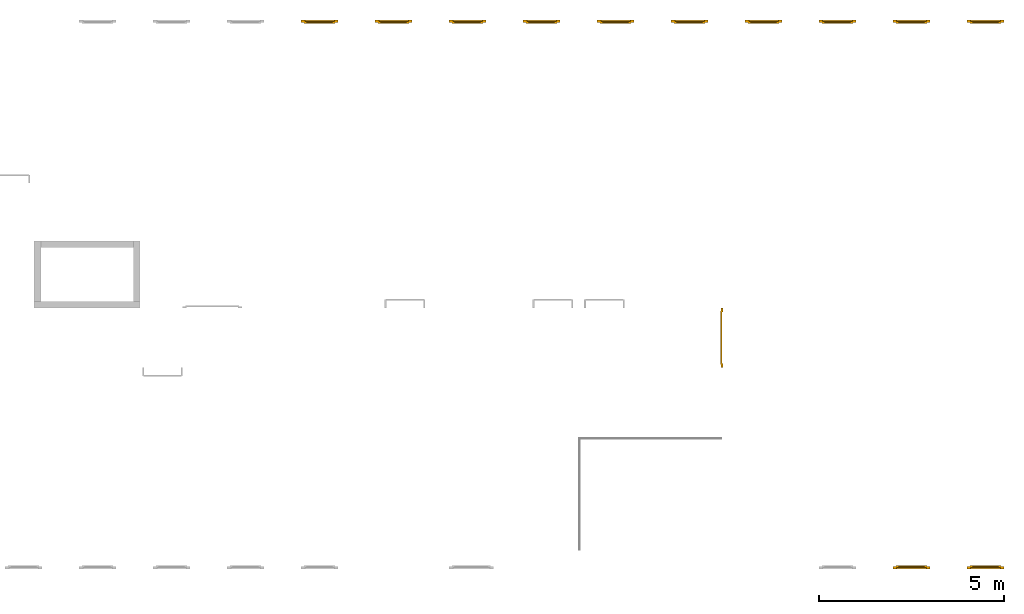
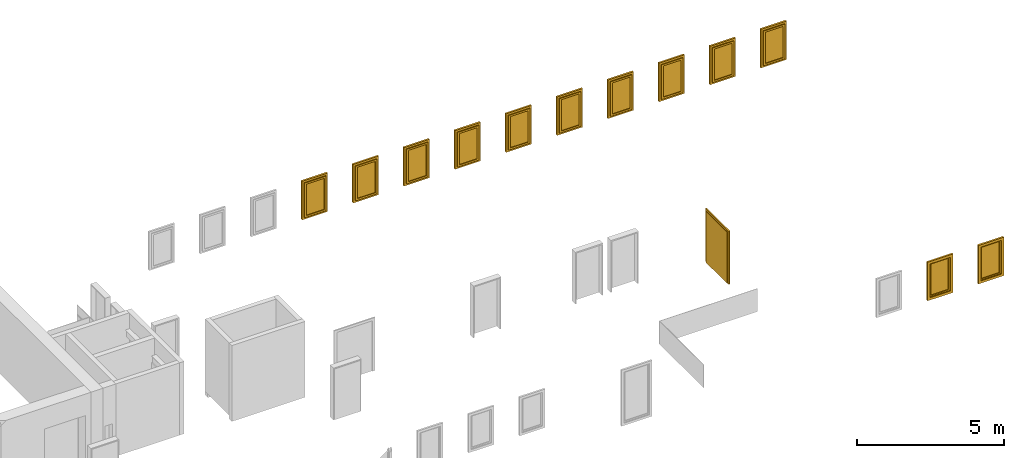
# One storey, part 4 of 5: 12 windows, 1 door.
"""IFC4 building model written with IfcOpenShell, lengths in metres."""

import ifcopenshell
import ifcopenshell.guid

model = None  # the IFC model being written
_history = None  # IfcOwnerHistory: only IFC2X3 demands one
_inside = {}  # id of a spatial element -> (the spatial element, [elements in it])
_under = {}  # id of a project, library or spatial element -> (it, [spatial elements below it])
_declared = {}  # id of a project -> (the project, [libraries it declares])
_typed = {}  # id of a type object -> (the type object, [elements of that type])
_made_of = {}  # id of a material, layer set ... -> (it, [elements and type objects made of it])


def new_model(schema):
    """Start an empty IFC model of exactly this schema.

    Asked for "IFC4X3", IfcOpenShell would pick the latest addendum, in which some entities
    have other attributes; the version numbers below select the first issue.
    IFC2X3 requires an IfcOwnerHistory on every rooted entity: one is made here for all.
    """
    global model, _history
    if schema == "IFC4X3":
        model = ifcopenshell.file(schema_version=(4, 3, 0, 0))
    else:
        model = ifcopenshell.file(schema=schema)
    _inside.clear()
    _under.clear()
    _declared.clear()
    _typed.clear()
    _made_of.clear()
    _history = None
    if model.schema == "IFC2X3":
        org = make("IfcOrganization", Name="unknown")
        user = make(
            "IfcPersonAndOrganization",
            ThePerson=make("IfcPerson", FamilyName="unknown"),
            TheOrganization=org,
        )
        app = make(
            "IfcApplication",
            ApplicationDeveloper=org,
            Version="unknown",
            ApplicationFullName="unknown",
            ApplicationIdentifier="unknown",
        )
        _history = make(
            "IfcOwnerHistory",
            OwningUser=user,
            OwningApplication=app,
            ChangeAction="ADDED",
            CreationDate=0,
        )
    return model


def make(cls, **values):
    """One entity of the class cls with the attributes given. An attribute that is None is left unset."""
    return model.create_entity(
        cls, **{name: value for name, value in values.items() if value is not None}
    )


def entity(cls, *values):
    """Any entity or typed value of the class cls, its attributes in the order of the schema. None: left unset."""
    e = model.create_entity(cls)
    for i, value in enumerate(values):
        if value is not None:
            e[i] = value
    return e


def rooted(cls, **values):
    """An entity with a GlobalId (a new one), such as an element, a storey or a relation."""
    return make(cls, GlobalId=ifcopenshell.guid.new(), OwnerHistory=_history, **values)


def si_unit(unit_type, name, prefix=None):
    """IfcSIUnit, for example si_unit("LENGTHUNIT", "METRE", prefix="MILLI")."""
    return make("IfcSIUnit", UnitType=unit_type, Prefix=prefix, Name=name)


def converted_unit(unit_type, name, factor, base, dimensions=None, offset=None):
    """IfcConversionBasedUnit, such as the inch: factor (a typed value) times the base unit."""
    return make(
        "IfcConversionBasedUnit"
        if offset is None
        else "IfcConversionBasedUnitWithOffset",
        ConversionOffset=offset,
        Dimensions=None
        if dimensions is None
        else entity("IfcDimensionalExponents", *dimensions),
        UnitType=unit_type,
        Name=name,
        ConversionFactor=make(
            "IfcMeasureWithUnit", ValueComponent=factor, UnitComponent=base
        ),
    )


def derived_unit(unit_type, elements):
    """IfcDerivedUnit: a product of units, each with its exponent."""
    return make(
        "IfcDerivedUnit",
        Elements=[
            make("IfcDerivedUnitElement", Unit=unit, Exponent=power)
            for unit, power in elements
        ],
        UnitType=unit_type,
    )


def assignment(units):
    """IfcUnitAssignment: the units of a project."""
    return None if units is None else make("IfcUnitAssignment", Units=units)


def point(xyz):
    """IfcCartesianPoint."""
    return None if xyz is None else make("IfcCartesianPoint", Coordinates=xyz)


def direction(xyz):
    """IfcDirection."""
    return None if xyz is None else make("IfcDirection", DirectionRatios=xyz)


def frame(location, z_axis=None, x_axis=None):
    """IfcAxis2Placement3D, a coordinate frame: its origin and axes. An axis left out is left unset."""
    return make(
        "IfcAxis2Placement3D",
        Location=point(location),
        Axis=direction(z_axis),
        RefDirection=direction(x_axis),
    )


def origin_with_axes():
    """The frame at (0, 0, 0) with the z axis (0, 0, 1) and the x axis (1, 0, 0) written out."""
    return frame((0.0, 0.0, 0.0), z_axis=(0.0, 0.0, 1.0), x_axis=(1.0, 0.0, 0.0))


def place(relative_to, where):
    """IfcLocalPlacement: puts the frame where relative to a parent placement (None: the world)."""
    return make(
        "IfcLocalPlacement", PlacementRelTo=relative_to, RelativePlacement=where
    )


def context(
    kind, dimensions, precision=None, world=None, true_north=None, identifier=None
):
    """IfcGeometricRepresentationContext, for example the 3D "Model" context."""
    return make(
        "IfcGeometricRepresentationContext",
        ContextIdentifier=identifier,
        ContextType=kind,
        CoordinateSpaceDimension=dimensions,
        Precision=precision,
        WorldCoordinateSystem=world,
        TrueNorth=true_north,
    )


def subcontext(parent, identifier, kind, view, scale=None):
    """IfcGeometricRepresentationSubContext, for example "Body" below "Model"."""
    return make(
        "IfcGeometricRepresentationSubContext",
        ContextIdentifier=identifier,
        ContextType=kind,
        ParentContext=parent,
        TargetScale=scale,
        TargetView=view,
    )


def project(units=None, contexts=None):
    """IfcProject with its units and contexts."""
    return rooted(
        "IfcProject",
        Name="project",
        RepresentationContexts=contexts,
        UnitsInContext=assignment(units),
    )


def spatial(cls, under=None, at=None, **own):
    """A site, building, storey or space (cls), placed at a placement, below another one or the project."""
    s = rooted(cls, ObjectPlacement=at, **own)
    if under is not None:
        _under.setdefault(under.id(), (under, []))[1].append(s)
    return s


def point_list(points):
    """IfcCartesianPointList2D or 3D."""
    cls = (
        "IfcCartesianPointList2D" if len(points[0]) == 2 else "IfcCartesianPointList3D"
    )
    return make(cls, CoordList=points)


def polygons(points, faces, closed=None, point_numbers=None):
    """IfcPolygonalFaceSet: a face is its outer loop, then its inner loops; points numbered from 1."""
    made = []
    for loops in faces:
        if len(loops) == 1:
            made.append(make("IfcIndexedPolygonalFace", CoordIndex=loops[0]))
        else:
            made.append(
                make(
                    "IfcIndexedPolygonalFaceWithVoids",
                    CoordIndex=loops[0],
                    InnerCoordIndices=loops[1:],
                )
            )
    return make(
        "IfcPolygonalFaceSet",
        Coordinates=point_list(points),
        Closed=closed,
        Faces=made,
        PnIndex=point_numbers,
    )


def shape(context_of_items, identifier, shape_type, items):
    """IfcShapeRepresentation: the items that make up one representation, for example the "Body"."""
    return make(
        "IfcShapeRepresentation",
        ContextOfItems=context_of_items,
        RepresentationIdentifier=identifier,
        RepresentationType=shape_type,
        Items=items,
    )


def source(mapping_origin, context_of_items, identifier, shape_type, items):
    """IfcRepresentationMap: a shape defined once, which mapped items show again and again."""
    return make(
        "IfcRepresentationMap",
        MappingOrigin=mapping_origin,
        MappedRepresentation=shape(context_of_items, identifier, shape_type, items),
    )


def transform(
    local_origin,
    x_axis=None,
    y_axis=None,
    z_axis=None,
    scale=None,
    scale2=None,
    scale3=None,
    uniform=True,
):
    """IfcCartesianTransformationOperator3D, or its non-uniform kind. x_axis, y_axis, z_axis: its Axis1, 2, 3."""
    if uniform:
        return make(
            "IfcCartesianTransformationOperator3D",
            Axis1=direction(x_axis),
            Axis2=direction(y_axis),
            LocalOrigin=point(local_origin),
            Scale=scale,
            Axis3=direction(z_axis),
        )
    return make(
        "IfcCartesianTransformationOperator3DnonUniform",
        Axis1=direction(x_axis),
        Axis2=direction(y_axis),
        LocalOrigin=point(local_origin),
        Scale=scale,
        Axis3=direction(z_axis),
        Scale2=scale2,
        Scale3=scale3,
    )


def mapped(mapping_source, mapping_target):
    """IfcMappedItem: shows the shape of a source again, moved by a transform."""
    return make(
        "IfcMappedItem", MappingSource=mapping_source, MappingTarget=mapping_target
    )


def made_of(thing, what):
    """Note that an element or type object is made of a material, layer set ...; save() writes the relation."""
    if what is not None:
        _made_of.setdefault(what.id(), (what, []))[1].append(thing)
    return thing


def type_object(cls, material=None, **own):
    """A type object (cls), such as IfcWallType, which elements share."""
    return made_of(rooted(cls, **own), material)


def element(
    cls,
    number,
    at=None,
    inside=None,
    cuts=None,
    type_object=None,
    material=None,
    context=None,
    identifier="Body",
    shape_type=None,
    held_by="IfcProductDefinitionShape",
    body=None,
    shapes=None,
    **own,
):
    """One element of the class cls, such as IfcWall. Its Tag is "e" and its number.

    at: its placement. inside: the storey or other place that contains it. cuts: it is an
    opening in that element (IfcRelVoidsElement). A single representation is given by context,
    identifier, shape_type and body (its items); several are given by shapes. held_by: the class
    of the entity that holds the representations. save() writes the other relations.
    """
    e = rooted(cls, Tag="e%d" % number, ObjectPlacement=at, **own)
    if body is not None:
        shapes = [shape(context, identifier, shape_type, body)]
    if shapes is not None:
        e.Representation = make(held_by, Representations=shapes)
    if inside is not None:
        _inside.setdefault(inside.id(), (inside, []))[1].append(e)
    if cuts is not None:
        rooted(
            "IfcRelVoidsElement", RelatingBuildingElement=cuts, RelatedOpeningElement=e
        )
    if type_object is not None:
        _typed.setdefault(type_object.id(), (type_object, []))[1].append(e)
    return made_of(e, material)


def aggregate(whole, parts):
    """IfcRelAggregates: a whole, such as a stair, and the parts it consists of."""
    return rooted("IfcRelAggregates", RelatingObject=whole, RelatedObjects=parts)


def save(model, path):
    """Write the relations noted so far, then the file.

    IfcRelAggregates (storeys below a building ...), IfcRelContainedInSpatialStructure (elements
    in a storey), IfcRelDefinesByType, IfcRelAssociatesMaterial and IfcRelDeclares: one each for
    every whole, place, type object, material and project.
    """
    for whole, parts in _under.values():
        aggregate(whole, parts)
    for where, things in _inside.values():
        rooted(
            "IfcRelContainedInSpatialStructure",
            RelatedElements=things,
            RelatingStructure=where,
        )
    for kind, things in _typed.values():
        rooted("IfcRelDefinesByType", RelatedObjects=things, RelatingType=kind)
    for what, things in _made_of.values():
        rooted("IfcRelAssociatesMaterial", RelatedObjects=things, RelatingMaterial=what)
    for by, libraries in _declared.values():
        rooted("IfcRelDeclares", RelatingContext=by, RelatedDefinitions=libraries)
    model.write(path)


model = new_model("IFC4")

# Units and contexts
model_context = context("Model", 3, precision=1e-05, world=origin_with_axes(), true_north=direction((0.0, 1.0)))
body_context = subcontext(model_context, "Body", "Model", "MODEL_VIEW")
ifc_project = project(units=[si_unit("LENGTHUNIT", "METRE"), si_unit("AREAUNIT", "SQUARE_METRE"), si_unit("VOLUMEUNIT", "CUBIC_METRE"), converted_unit("PLANEANGLEUNIT", "DEGREE", entity("IfcPlaneAngleMeasure", 0.0174532925199433), si_unit("PLANEANGLEUNIT", "RADIAN"), dimensions=[0, 0, 0, 0, 0, 0, 0]), converted_unit("TIMEUNIT", "Year", entity("IfcTimeMeasure", 31557600.0), si_unit("TIMEUNIT", "SECOND"), dimensions=[0, 0, 1, 0, 0, 0, 0]), si_unit("MASSUNIT", "GRAM", prefix="KILO"), si_unit("THERMODYNAMICTEMPERATUREUNIT", "DEGREE_CELSIUS"), si_unit("LUMINOUSINTENSITYUNIT", "LUMEN"), si_unit("ENERGYUNIT", "JOULE", prefix="MEGA"), derived_unit("THERMALCONDUCTANCEUNIT", [(si_unit("POWERUNIT", "WATT"), 1), (si_unit("LENGTHUNIT", "METRE"), -1), (si_unit("THERMODYNAMICTEMPERATUREUNIT", "KELVIN"), -1)]), derived_unit("SPECIFICHEATCAPACITYUNIT", [(si_unit("ENERGYUNIT", "JOULE"), 1), (si_unit("MASSUNIT", "GRAM", prefix="KILO"), -1), (si_unit("THERMODYNAMICTEMPERATUREUNIT", "KELVIN"), -1)]), derived_unit("MASSDENSITYUNIT", [(si_unit("MASSUNIT", "GRAM", prefix="KILO"), 1), (si_unit("VOLUMEUNIT", "CUBIC_METRE"), -1)])], contexts=[model_context])

# Site, building, storey
site_placement = place(None, origin_with_axes())
site = spatial("IfcSite", under=ifc_project, at=site_placement, CompositionType="ELEMENT")
building_placement = place(None, origin_with_axes())
building = spatial("IfcBuilding", under=site, at=building_placement, CompositionType="ELEMENT")
storey_placement = place(None, frame((0.0, 0.0, 4.5), z_axis=(0.0, 0.0, 1.0), x_axis=(1.0, 0.0, 0.0)))
storey = spatial("IfcBuildingStorey", under=building, at=storey_placement, Name="1 OG", CompositionType="ELEMENT", Elevation=4.5)

# Windows
window_type = type_object("IfcWindowType", Name="1-27", PartitioningType="SINGLE_PANEL", PredefinedType="WINDOW")
shared_shape_1 = source(origin_with_axes(), body_context, "Body", "Tessellation", [
    polygons([(-0.5, -0.07, 0.0), (-0.5, 0.0, 0.0), (-0.4, 0.0, 0.1), (-0.4, -0.07, 0.1), (-0.5, -0.07, 1.6), (-0.5, 0.0, 1.6), (-0.4, 0.0, 1.5), (-0.4, -0.07, 1.5)], [[[1, 2, 3, 4]], [[5, 6, 2, 1]], [[2, 6, 7, 3]], [[4, 3, 7, 8]], [[1, 4, 8, 5]], [[8, 7, 6, 5]]], closed=True),
    polygons([(0.5, -0.07, 0.0), (0.5, 0.0, 0.0), (0.5, 0.0, 1.6), (0.5, -0.07, 1.6), (0.4, -0.07, 0.1), (0.4, 0.0, 0.1), (0.4, 0.0, 1.5), (0.4, -0.07, 1.5)], [[[1, 2, 3, 4]], [[5, 6, 2, 1]], [[2, 6, 7, 3]], [[4, 3, 7, 8]], [[1, 4, 8, 5]], [[8, 7, 6, 5]]], closed=True),
    polygons([(-0.5, -0.07, 0.0), (-0.5, 0.0, 0.0), (0.5, 0.0, 0.0), (0.5, -0.07, 0.0), (-0.4, -0.07, 0.1), (-0.4, 0.0, 0.1), (0.0, 0.0, 0.1), (0.4, 0.0, 0.1), (0.4, -0.07, 0.1), (0.0, -0.07, 0.1)], [[[1, 2, 3, 4]], [[5, 6, 2, 1]], [[2, 6, 7, 8, 3]], [[4, 3, 8, 9]], [[1, 4, 9, 10, 5]], [[10, 7, 6, 5]], [[9, 8, 7, 10]]], closed=True),
    polygons([(-0.5, -0.07, 1.6), (-0.5, 0.0, 1.6), (-0.4, 0.0, 1.5), (-0.4, -0.07, 1.5), (0.5, -0.07, 1.6), (0.5, 0.0, 1.6), (0.4, 0.0, 1.5), (0.0, 0.0, 1.5), (0.0, -0.07, 1.5), (0.4, -0.07, 1.5)], [[[1, 2, 3, 4]], [[5, 6, 2, 1]], [[2, 6, 7, 8, 3]], [[4, 3, 8, 9]], [[1, 4, 9, 10, 5]], [[10, 7, 6, 5]], [[9, 8, 7, 10]]], closed=True),
    polygons([(-0.42, 0.0, 0.08), (-0.42, 0.03, 0.08), (-0.35, 0.03, 0.15), (-0.35, 0.0, 0.15), (-0.42, 0.0, 1.52), (-0.42, 0.03, 1.52), (-0.35, 0.03, 1.45), (-0.35, 0.0, 1.45)], [[[1, 2, 3, 4]], [[5, 6, 2, 1]], [[2, 6, 7, 3]], [[4, 3, 7, 8]], [[1, 4, 8, 5]], [[8, 7, 6, 5]]], closed=True),
    polygons([(0.42, 0.0, 0.08), (0.35, 0.0, 0.15), (0.35, 0.03, 0.15), (0.42, 0.03, 0.08), (0.42, 0.0, 1.52), (0.35, 0.0, 1.45), (0.35, 0.03, 1.45), (0.42, 0.03, 1.52)], [[[1, 2, 3, 4]], [[1, 5, 6, 2]], [[2, 6, 7, 3]], [[4, 3, 7, 8]], [[5, 1, 4, 8]], [[6, 5, 8, 7]]], closed=True),
    polygons([(-0.42, 0.0, 0.08), (-0.42, 0.03, 0.08), (0.42, 0.03, 0.08), (0.42, 0.0, 0.08), (-0.35, 0.0, 0.15), (-0.35, 0.03, 0.15), (0.35, 0.03, 0.15), (0.35, 0.0, 0.15)], [[[1, 2, 3, 4]], [[5, 6, 2, 1]], [[2, 6, 7, 3]], [[4, 3, 7, 8]], [[1, 4, 8, 5]], [[8, 7, 6, 5]]], closed=True),
    polygons([(-0.42, 0.0, 1.52), (0.42, 0.0, 1.52), (0.42, 0.03, 1.52), (-0.42, 0.03, 1.52), (-0.35, 0.0, 1.45), (0.35, 0.0, 1.45), (0.35, 0.03, 1.45), (-0.35, 0.03, 1.45)], [[[1, 2, 3, 4]], [[1, 5, 6, 2]], [[2, 6, 7, 3]], [[4, 3, 7, 8]], [[5, 1, 4, 8]], [[6, 5, 8, 7]]], closed=True),
    polygons([(-0.4, -0.03, 0.1), (-0.4, 0.0, 0.1), (-0.35, 0.0, 0.15), (-0.35, -0.03, 0.15), (-0.4, -0.03, 1.5), (-0.4, 0.0, 1.5), (-0.35, 0.0, 1.45), (-0.35, -0.03, 1.45)], [[[1, 2, 3, 4]], [[5, 6, 2, 1]], [[2, 6, 7, 3]], [[4, 3, 7, 8]], [[1, 4, 8, 5]], [[8, 7, 6, 5]]], closed=True),
    polygons([(0.4, -0.03, 0.1), (0.35, -0.03, 0.15), (0.35, 0.0, 0.15), (0.4, 0.0, 0.1), (0.4, -0.03, 1.5), (0.35, -0.03, 1.45), (0.35, 0.0, 1.45), (0.4, 0.0, 1.5)], [[[1, 2, 3, 4]], [[1, 5, 6, 2]], [[2, 6, 7, 3]], [[4, 3, 7, 8]], [[5, 1, 4, 8]], [[6, 5, 8, 7]]], closed=True),
    polygons([(-0.4, -0.03, 0.1), (-0.4, 0.0, 0.1), (0.4, 0.0, 0.1), (0.4, -0.03, 0.1), (-0.35, -0.03, 0.15), (-0.35, 0.0, 0.15), (0.35, 0.0, 0.15), (0.35, -0.03, 0.15)], [[[1, 2, 3, 4]], [[5, 6, 2, 1]], [[2, 6, 7, 3]], [[4, 3, 7, 8]], [[1, 4, 8, 5]], [[8, 7, 6, 5]]], closed=True),
    polygons([(-0.4, -0.03, 1.5), (0.4, -0.03, 1.5), (0.4, 0.0, 1.5), (-0.4, 0.0, 1.5), (-0.35, -0.03, 1.45), (0.35, -0.03, 1.45), (0.35, 0.0, 1.45), (-0.35, 0.0, 1.45)], [[[1, 2, 3, 4]], [[1, 5, 6, 2]], [[2, 6, 7, 3]], [[4, 3, 7, 8]], [[5, 1, 4, 8]], [[6, 5, 8, 7]]], closed=True),
    polygons([(-0.35, -0.00500000000000001, 0.15), (-0.35, 0.00499999999999999, 0.15), (0.35, 0.00499999999999999, 0.15), (0.35, -0.00500000000000001, 0.15), (-0.35, -0.00500000000000001, 1.45), (-0.35, 0.00499999999999999, 1.45), (0.35, 0.00499999999999999, 1.45), (0.35, -0.00500000000000001, 1.45)], [[[1, 2, 3, 4]], [[5, 6, 2, 1]], [[2, 6, 7, 3]], [[4, 3, 7, 8]], [[1, 4, 8, 5]], [[8, 7, 6, 5]]], closed=True),
])
window_1_placement = place(None, frame((58.723, 0.0, 5.5), z_axis=(0.0, 0.0, 1.0), x_axis=(1.0, 0.0, 0.0)))
element("IfcWindow", 1, at=window_1_placement, inside=storey, type_object=window_type, Name="Fenster-001", OverallHeight=1.6, OverallWidth=1.0, context=body_context, shape_type="MappedRepresentation", body=[
    mapped(shared_shape_1, transform((0.5, 0.07, 0.0))),
])
window_2_placement = place(None, frame((56.723, 0.0, 5.5), z_axis=(0.0, 0.0, 1.0), x_axis=(1.0, 0.0, 0.0)))
element("IfcWindow", 2, at=window_2_placement, inside=storey, type_object=window_type, Name="Fenster-001", OverallHeight=1.6, OverallWidth=1.0, context=body_context, shape_type="MappedRepresentation", body=[
    mapped(shared_shape_1, transform((0.5, 0.0700000000000004, 0.0))),
])
shared_shape_2 = source(origin_with_axes(), body_context, "Body", "Tessellation", [
    polygons([(0.5, -0.07, 0.0), (0.4, -0.07, 0.1), (0.4, 0.0, 0.1), (0.5, 0.0, 0.0), (0.5, -0.07, 1.6), (0.4, -0.07, 1.5), (0.4, 0.0, 1.5), (0.5, 0.0, 1.6)], [[[1, 2, 3, 4]], [[1, 5, 6, 2]], [[2, 6, 7, 3]], [[4, 3, 7, 8]], [[5, 1, 4, 8]], [[6, 5, 8, 7]]], closed=True),
    polygons([(-0.5, -0.07, 0.0), (-0.5, -0.07, 1.6), (-0.5, 0.0, 1.6), (-0.5, 0.0, 0.0), (-0.4, -0.07, 0.1), (-0.4, -0.07, 1.5), (-0.4, 0.0, 1.5), (-0.4, 0.0, 0.1)], [[[1, 2, 3, 4]], [[1, 5, 6, 2]], [[2, 6, 7, 3]], [[4, 3, 7, 8]], [[5, 1, 4, 8]], [[6, 5, 8, 7]]], closed=True),
    polygons([(0.5, -0.07, 0.0), (-0.5, -0.07, 0.0), (-0.5, 0.0, 0.0), (0.5, 0.0, 0.0), (0.4, -0.07, 0.1), (0.0, -0.07, 0.1), (-0.4, -0.07, 0.1), (-0.4, 0.0, 0.1), (0.0, 0.0, 0.1), (0.4, 0.0, 0.1)], [[[1, 2, 3, 4]], [[1, 5, 6, 7, 2]], [[2, 7, 8, 3]], [[4, 3, 8, 9, 10]], [[5, 1, 4, 10]], [[6, 5, 10, 9]], [[7, 6, 9, 8]]], closed=True),
    polygons([(0.5, -0.07, 1.6), (0.4, -0.07, 1.5), (0.4, 0.0, 1.5), (0.5, 0.0, 1.6), (-0.5, -0.07, 1.6), (-0.4, -0.07, 1.5), (0.0, -0.07, 1.5), (0.0, 0.0, 1.5), (-0.4, 0.0, 1.5), (-0.5, 0.0, 1.6)], [[[1, 2, 3, 4]], [[1, 5, 6, 7, 2]], [[2, 7, 8, 3]], [[4, 3, 8, 9, 10]], [[5, 1, 4, 10]], [[6, 5, 10, 9]], [[7, 6, 9, 8]]], closed=True),
    polygons([(0.42, 0.0, 0.08), (0.35, 0.0, 0.15), (0.35, 0.03, 0.15), (0.42, 0.03, 0.08), (0.42, 0.0, 1.52), (0.35, 0.0, 1.45), (0.35, 0.03, 1.45), (0.42, 0.03, 1.52)], [[[1, 2, 3, 4]], [[1, 5, 6, 2]], [[2, 6, 7, 3]], [[4, 3, 7, 8]], [[5, 1, 4, 8]], [[6, 5, 8, 7]]], closed=True),
    polygons([(-0.42, 0.0, 0.08), (-0.42, 0.03, 0.08), (-0.35, 0.03, 0.15), (-0.35, 0.0, 0.15), (-0.42, 0.0, 1.52), (-0.42, 0.03, 1.52), (-0.35, 0.03, 1.45), (-0.35, 0.0, 1.45)], [[[1, 2, 3, 4]], [[5, 6, 2, 1]], [[2, 6, 7, 3]], [[4, 3, 7, 8]], [[1, 4, 8, 5]], [[8, 7, 6, 5]]], closed=True),
    polygons([(0.42, 0.0, 0.08), (-0.42, 0.0, 0.08), (-0.42, 0.03, 0.08), (0.42, 0.03, 0.08), (0.35, 0.0, 0.15), (-0.35, 0.0, 0.15), (-0.35, 0.03, 0.15), (0.35, 0.03, 0.15)], [[[1, 2, 3, 4]], [[1, 5, 6, 2]], [[2, 6, 7, 3]], [[4, 3, 7, 8]], [[5, 1, 4, 8]], [[6, 5, 8, 7]]], closed=True),
    polygons([(0.42, 0.0, 1.52), (0.42, 0.03, 1.52), (-0.42, 0.03, 1.52), (-0.42, 0.0, 1.52), (0.35, 0.0, 1.45), (0.35, 0.03, 1.45), (-0.35, 0.03, 1.45), (-0.35, 0.0, 1.45)], [[[1, 2, 3, 4]], [[5, 6, 2, 1]], [[2, 6, 7, 3]], [[4, 3, 7, 8]], [[1, 4, 8, 5]], [[8, 7, 6, 5]]], closed=True),
    polygons([(0.4, -0.03, 0.1), (0.35, -0.03, 0.15), (0.35, 0.0, 0.15), (0.4, 0.0, 0.1), (0.4, -0.03, 1.5), (0.35, -0.03, 1.45), (0.35, 0.0, 1.45), (0.4, 0.0, 1.5)], [[[1, 2, 3, 4]], [[1, 5, 6, 2]], [[2, 6, 7, 3]], [[4, 3, 7, 8]], [[5, 1, 4, 8]], [[6, 5, 8, 7]]], closed=True),
    polygons([(-0.4, -0.03, 0.1), (-0.4, 0.0, 0.1), (-0.35, 0.0, 0.15), (-0.35, -0.03, 0.15), (-0.4, -0.03, 1.5), (-0.4, 0.0, 1.5), (-0.35, 0.0, 1.45), (-0.35, -0.03, 1.45)], [[[1, 2, 3, 4]], [[5, 6, 2, 1]], [[2, 6, 7, 3]], [[4, 3, 7, 8]], [[1, 4, 8, 5]], [[8, 7, 6, 5]]], closed=True),
    polygons([(0.4, -0.03, 0.1), (-0.4, -0.03, 0.1), (-0.4, 0.0, 0.1), (0.4, 0.0, 0.1), (0.35, -0.03, 0.15), (-0.35, -0.03, 0.15), (-0.35, 0.0, 0.15), (0.35, 0.0, 0.15)], [[[1, 2, 3, 4]], [[1, 5, 6, 2]], [[2, 6, 7, 3]], [[4, 3, 7, 8]], [[5, 1, 4, 8]], [[6, 5, 8, 7]]], closed=True),
    polygons([(0.4, -0.03, 1.5), (0.4, 0.0, 1.5), (-0.4, 0.0, 1.5), (-0.4, -0.03, 1.5), (0.35, -0.03, 1.45), (0.35, 0.0, 1.45), (-0.35, 0.0, 1.45), (-0.35, -0.03, 1.45)], [[[1, 2, 3, 4]], [[5, 6, 2, 1]], [[2, 6, 7, 3]], [[4, 3, 7, 8]], [[1, 4, 8, 5]], [[8, 7, 6, 5]]], closed=True),
    polygons([(0.35, -0.00500000000000001, 0.15), (-0.35, -0.00500000000000001, 0.15), (-0.35, 0.00499999999999999, 0.15), (0.35, 0.00499999999999999, 0.15), (0.35, -0.00500000000000001, 1.45), (-0.35, -0.00500000000000001, 1.45), (-0.35, 0.00499999999999999, 1.45), (0.35, 0.00499999999999999, 1.45)], [[[1, 2, 3, 4]], [[1, 5, 6, 2]], [[2, 6, 7, 3]], [[4, 3, 7, 8]], [[5, 1, 4, 8]], [[6, 5, 8, 7]]], closed=True),
])
for number, where, z_axis, x_axis, name in (
    (3, (47.723, 14.8459998909351, 5.5), (0.0, 0.0, 1.0), (-1.0, 0.0, 0.0), "Fenster-001"),
    (4, (57.723, 14.8459998909351, 5.5), (0.0, 0.0, 1.0), (-1.0, 0.0, 0.0), "Fenster-001"),
    (5, (51.723, 14.8459998909351, 5.5), (0.0, 0.0, 1.0), (-1.0, 0.0, 0.0), "Fenster-001"),
):
    element("IfcWindow", number, at=place(None, frame(where, z_axis=z_axis, x_axis=x_axis)), inside=storey, type_object=window_type, Name=name, OverallHeight=1.6, OverallWidth=1.0, context=body_context, shape_type="MappedRepresentation", body=[
        mapped(shared_shape_2, transform((0.5, 0.0700000000000003, 0.0))),
    ])
for number, where, z_axis, x_axis, name in (
    (6, (41.723, 14.8459998909351, 5.5), (0.0, 0.0, 1.0), (-1.0, 0.0, 0.0), "Fenster-001"),
    (7, (43.723, 14.8459998909351, 5.5), (0.0, 0.0, 1.0), (-1.0, 0.0, 0.0), "Fenster-001"),
):
    element("IfcWindow", number, at=place(None, frame(where, z_axis=z_axis, x_axis=x_axis)), inside=storey, type_object=window_type, Name=name, OverallHeight=1.6, OverallWidth=1.0, context=body_context, shape_type="MappedRepresentation", body=[
        mapped(shared_shape_2, transform((0.5, 0.0699999999999985, 0.0))),
    ])
for number, where, z_axis, x_axis, name in (
    (8, (59.723, 14.8459998909351, 5.5), (0.0, 0.0, 1.0), (-1.0, 0.0, 0.0), "Fenster-001"),
    (9, (49.723, 14.8459998909351, 5.5), (0.0, 0.0, 1.0), (-1.0, 0.0, 0.0), "Fenster-001"),
    (10, (55.723, 14.8459998909351, 5.5), (0.0, 0.0, 1.0), (-1.0, 0.0, 0.0), "Fenster-001"),
    (11, (45.723, 14.8459998909351, 5.5), (0.0, 0.0, 1.0), (-1.0, 0.0, 0.0), "Fenster-001"),
    (12, (53.723, 14.8459998909351, 5.5), (0.0, 0.0, 1.0), (-1.0, 0.0, 0.0), "Fenster-001"),
):
    element("IfcWindow", number, at=place(None, frame(where, z_axis=z_axis, x_axis=x_axis)), inside=storey, type_object=window_type, Name=name, OverallHeight=1.6, OverallWidth=1.0, context=body_context, shape_type="MappedRepresentation", body=[
        mapped(shared_shape_2, transform((0.5, 0.0700000000000003, 0.0))),
    ])

# Door
door_type = type_object("IfcDoorType", Name="2-Fl 27", OperationType="DOUBLE_DOOR_SINGLE_SWING", PredefinedType="DOOR")
shared_shape_3 = source(origin_with_axes(), body_context, "Body", "Tessellation", [
    polygons([(0.8, -0.05, 0.0), (0.8, -0.02, 0.0), (0.8, -0.02, 2.2), (0.8, -0.05, 2.2), (0.7, -0.05, 0.0), (0.7, -0.02, 0.0), (0.7, -0.02, 2.1), (0.1251, -0.02, 2.1), (0.0001, -0.02, 2.1), (-0.7, -0.02, 2.1), (-0.7, -0.02, 0.0), (-0.8, -0.02, 0.0), (-0.8, -0.02, 2.2), (-0.8, -0.05, 2.2), (-0.8, -0.05, 0.0), (-0.7, -0.05, 0.0), (-0.7, -0.05, 2.1), (0.0001, -0.05, 2.1), (0.1251, -0.05, 2.1), (0.7, -0.05, 2.1)], [[[1, 2, 3, 4]], [[5, 6, 2, 1]], [[2, 6, 7, 8, 9, 10, 11, 12, 13, 3]], [[4, 3, 13, 14]], [[1, 4, 14, 15, 16, 17, 18, 19, 20, 5]], [[20, 7, 6, 5]], [[19, 8, 7, 20]], [[18, 9, 8, 19]], [[17, 10, 9, 18]], [[16, 11, 10, 17]], [[15, 12, 11, 16]], [[14, 13, 12, 15]]], closed=True),
    polygons([(0.8, -0.02, 0.0), (0.8, 0.0, 0.0), (0.8, 0.0, 2.2), (0.8, -0.02, 2.2), (0.725, -0.02, 0.0), (0.725, 0.0, 0.0), (0.725, 0.0, 2.125), (0.1001, 0.0, 2.125), (0.0251, 0.0, 2.125), (-0.725, 0.0, 2.125), (-0.725, 0.0, 0.0), (-0.8, 0.0, 0.0), (-0.8, 0.0, 2.2), (-0.8, -0.02, 2.2), (-0.8, -0.02, 0.0), (-0.725, -0.02, 0.0), (-0.725, -0.02, 2.125), (0.0251, -0.02, 2.125), (0.1001, -0.02, 2.125), (0.725, -0.02, 2.125)], [[[1, 2, 3, 4]], [[5, 6, 2, 1]], [[2, 6, 7, 8, 9, 10, 11, 12, 13, 3]], [[4, 3, 13, 14]], [[1, 4, 14, 15, 16, 17, 18, 19, 20, 5]], [[20, 7, 6, 5]], [[19, 8, 7, 20]], [[18, 9, 8, 19]], [[17, 10, 9, 18]], [[16, 11, 10, 17]], [[15, 12, 11, 16]], [[14, 13, 12, 15]]], closed=True),
    polygons([(0.725, 0.02, 0.0), (0.000499999999999945, 0.02, 0.0), (0.000499999999999945, 0.02, 2.125), (0.725, 0.02, 2.125), (0.725, -0.02, 0.0), (0.000499999999999945, -0.02, 0.0), (0.000499999999999945, -0.02, 2.125), (0.725, -0.02, 2.125)], [[[1, 2, 3, 4]], [[2, 1, 5, 6]], [[3, 2, 6, 7]], [[4, 3, 7, 8]], [[1, 4, 8, 5]], [[6, 5, 8, 7]]], closed=True),
    polygons([(-0.725, 0.02, 0.0), (-0.725, 0.02, 2.125), (-0.000499999999999945, 0.02, 2.125), (-0.000499999999999945, 0.02, 0.0), (-0.725, -0.02, 0.0), (-0.725, -0.02, 2.125), (-0.000499999999999945, -0.02, 2.125), (-0.000499999999999945, -0.02, 0.0)], [[[1, 2, 3, 4]], [[1, 5, 6, 2]], [[2, 6, 7, 3]], [[3, 7, 8, 4]], [[4, 8, 5, 1]], [[8, 7, 6, 5]]], closed=True),
])
door_placement = place(None, frame((52.078, 5.55499994546756, 4.5), z_axis=(0.0, 0.0, 1.0), x_axis=(0.0, 1.0, 0.0)))
element("IfcDoor", 13, at=door_placement, inside=storey, type_object=door_type, OverallHeight=2.2, OverallWidth=1.6, context=body_context, shape_type="MappedRepresentation", body=[
    mapped(shared_shape_3, transform((0.7, 0.0, 0.0))),
])

save(model, "model.ifc")
